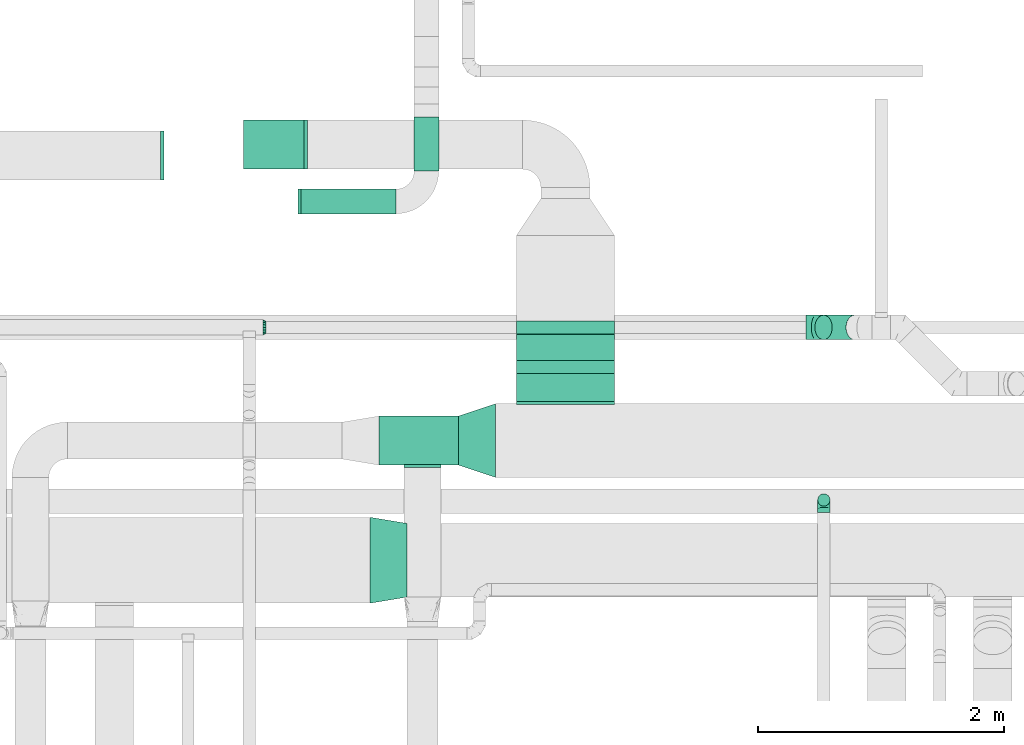
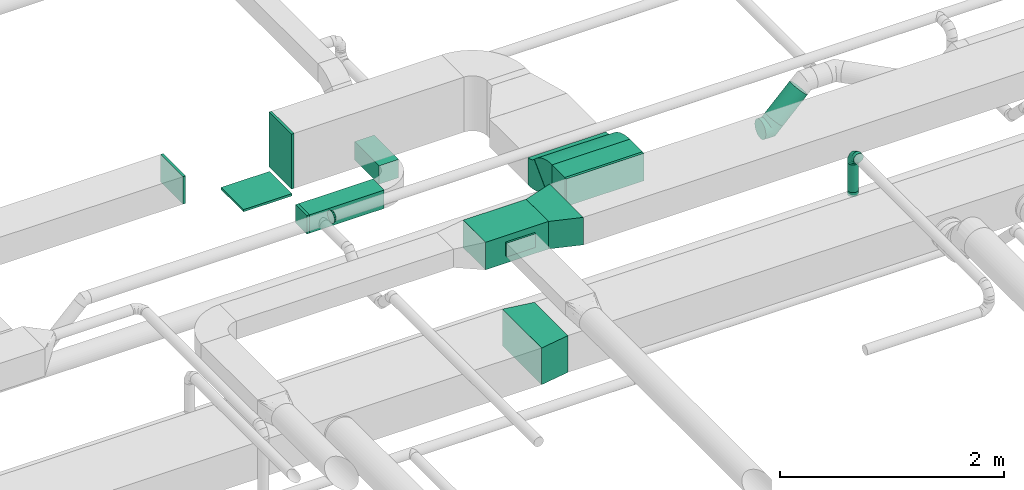
# One storey, part 39 of 60: 14 flow fittings, 7 flow segments.
"""IFC2X3 building model written with IfcOpenShell, lengths in millimetres."""

from ifc_helpers import new_model, entity, si_unit, converted_unit, derived_unit, direction, frame, frame_2d, origin, origin_2d_with_axis, place, context, subcontext, project, spatial, polyline, circle_curve, parameter, trimmed, segment, composite_curve, rectangle, circle, outline, extrude, faceted_brep, source, transform, mapped, material, type_object, type_shapes, element, save


model = new_model("IFC2X3")

# Units and contexts
model_context = context("Model", 3, precision=0.01, world=origin(), true_north=direction((6.12303176911189e-17, 1.0)))
body_context = subcontext(model_context, "Body", "Model", "MODEL_VIEW")
ifc_project = project(units=[si_unit("LENGTHUNIT", "METRE", prefix="MILLI"), si_unit("AREAUNIT", "SQUARE_METRE"), si_unit("VOLUMEUNIT", "CUBIC_METRE"), converted_unit("PLANEANGLEUNIT", "DEGREE", entity("IfcRatioMeasure", 0.0174532925199433), si_unit("PLANEANGLEUNIT", "RADIAN"), dimensions=[0, 0, 0, 0, 0, 0, 0]), si_unit("MASSUNIT", "GRAM", prefix="KILO"), derived_unit("MASSDENSITYUNIT", [(si_unit("MASSUNIT", "GRAM", prefix="KILO"), 1), (si_unit("LENGTHUNIT", "METRE"), -3)]), derived_unit("MOMENTOFINERTIAUNIT", [(si_unit("LENGTHUNIT", "METRE"), 4)]), si_unit("TIMEUNIT", "SECOND"), si_unit("FREQUENCYUNIT", "HERTZ"), si_unit("THERMODYNAMICTEMPERATUREUNIT", "DEGREE_CELSIUS"), derived_unit("THERMALTRANSMITTANCEUNIT", [(si_unit("MASSUNIT", "GRAM", prefix="KILO"), 1), (si_unit("THERMODYNAMICTEMPERATUREUNIT", "KELVIN"), -1), (si_unit("TIMEUNIT", "SECOND"), -3)]), derived_unit("VOLUMETRICFLOWRATEUNIT", [(si_unit("LENGTHUNIT", "METRE"), 3), (si_unit("TIMEUNIT", "SECOND"), -1)]), derived_unit("MASSFLOWRATEUNIT", [(si_unit("MASSUNIT", "GRAM", prefix="KILO"), 1), (si_unit("TIMEUNIT", "SECOND"), -1)]), derived_unit("ROTATIONALFREQUENCYUNIT", [(si_unit("TIMEUNIT", "SECOND"), -1)]), si_unit("ELECTRICCURRENTUNIT", "AMPERE"), si_unit("ELECTRICVOLTAGEUNIT", "VOLT"), si_unit("POWERUNIT", "WATT"), si_unit("FORCEUNIT", "NEWTON", prefix="KILO"), si_unit("ILLUMINANCEUNIT", "LUX"), si_unit("LUMINOUSFLUXUNIT", "LUMEN"), si_unit("LUMINOUSINTENSITYUNIT", "CANDELA"), derived_unit("USERDEFINED", [(si_unit("MASSUNIT", "GRAM", prefix="KILO"), -1), (si_unit("LENGTHUNIT", "METRE"), -2), (si_unit("TIMEUNIT", "SECOND"), 3), (si_unit("LUMINOUSFLUXUNIT", "LUMEN"), 1)]), derived_unit("LINEARVELOCITYUNIT", [(si_unit("LENGTHUNIT", "METRE"), 1), (si_unit("TIMEUNIT", "SECOND"), -1)]), si_unit("PRESSUREUNIT", "PASCAL"), derived_unit("USERDEFINED", [(si_unit("LENGTHUNIT", "METRE"), -2), (si_unit("MASSUNIT", "GRAM", prefix="KILO"), 1), (si_unit("TIMEUNIT", "SECOND"), -2)]), derived_unit("LINEARFORCEUNIT", [(si_unit("MASSUNIT", "GRAM", prefix="KILO"), 1), (si_unit("LENGTHUNIT", "METRE"), 1), (si_unit("TIMEUNIT", "SECOND"), -2), (si_unit("LENGTHUNIT", "METRE"), -1)]), derived_unit("PLANARFORCEUNIT", [(si_unit("MASSUNIT", "GRAM", prefix="KILO"), 1), (si_unit("LENGTHUNIT", "METRE"), 1), (si_unit("TIMEUNIT", "SECOND"), -2), (si_unit("LENGTHUNIT", "METRE"), -2)])], contexts=[model_context])

# Site, building, storey
site_placement = place(None, origin())
site = spatial("IfcSite", under=ifc_project, at=site_placement, CompositionType="ELEMENT")
building_placement = place(site_placement, origin())
building = spatial("IfcBuilding", under=site, at=building_placement, CompositionType="ELEMENT")
storey_placement = place(building_placement, frame((0.0, 0.0, 19800.0)))
storey = spatial("IfcBuildingStorey", under=building, at=storey_placement, CompositionType="ELEMENT", Elevation=19800.0)

# Flow segments
duct_segment_type_1 = type_object("IfcDuctSegmentType", PredefinedType="NOTDEFINED")
flow_segment_1_placement = place(storey_placement, frame((53402.88, 9163.95, 3420.0)))
element("IfcFlowSegment", 1, at=flow_segment_1_placement, inside=storey, type_object=duct_segment_type_1, context=body_context, shape_type="SweptSolid", body=[
    extrude(rectangle(XDim=650.000000000069, YDim=400.0, at=origin_2d_with_axis()), frame((325.0, 200.0, 0.0)), (0.0, 0.0, 1.0), 300.000000000001),
])
flow_segment_2_placement = place(storey_placement, frame((52770.03, 11210.73, 2800.0)))
element("IfcFlowSegment", 2, at=flow_segment_2_placement, inside=storey, type_object=duct_segment_type_1, context=body_context, shape_type="SweptSolid", body=[
    extrude(rectangle(XDim=770.426926812535, YDim=200.0, at=origin_2d_with_axis()), frame((385.21, 100.0, 0.0)), (0.0, 0.0, 1.0), 199.999999999998),
])
flow_segment_3_placement = place(storey_placement, frame((53690.46, 11560.73, 2800.0)))
element("IfcFlowSegment", 3, at=flow_segment_3_placement, inside=storey, type_object=duct_segment_type_1, context=body_context, shape_type="SweptSolid", body=[
    extrude(rectangle(XDim=436.446609406733, YDim=199.999999999998, at=origin_2d_with_axis()), frame((100.0, 218.22, 0.0), z_axis=(0.0, 0.0, 1.0), x_axis=(0.0, 1.0, 0.0)), (0.0, 0.0, 1.0), 199.999999999998),
])
flow_segment_4_placement = place(storey_placement, frame((54521.8, 10017.07, 3371.8)))
element("IfcFlowSegment", 4, at=flow_segment_4_placement, inside=storey, type_object=duct_segment_type_1, context=body_context, shape_type="SweptSolid", body=[
    extrude(rectangle(XDim=6.03030380317478, YDim=299.999999999998, at=origin_2d_with_axis()), frame((0.0, 108.2, 108.2), z_axis=(1.0, 0.0, 0.0), x_axis=(0.0, -0.707106781186548, 0.707106781186548)), (0.0, 0.0, 1.0), 800.000000000008),
])
flow_segment_5_placement = place(storey_placement, frame((54521.8, 9683.95, 3420.0)))
element("IfcFlowSegment", 5, at=flow_segment_5_placement, inside=storey, type_object=duct_segment_type_1, context=body_context, shape_type="SweptSolid", body=[
    extrude(rectangle(XDim=227.051120466258, YDim=800.0, at=origin_2d_with_axis()), frame((400.0, 113.53, 0.0), z_axis=(0.0, 0.0, 1.0), x_axis=(0.0, 1.0, 0.0)), (0.0, 0.0, 1.0), 300.000000000001),
])
duct_segment_type_2 = type_object("IfcDuctSegmentType", PredefinedType="NOTDEFINED")
flow_segment_6_placement = place(storey_placement, frame((56974.72, 8828.41, 3199.5)))
element("IfcFlowSegment", 6, at=flow_segment_6_placement, inside=storey, type_object=duct_segment_type_2, context=body_context, shape_type="SweptSolid", body=[
    extrude(circle(Radius=50.0, at=origin_2d_with_axis()), frame((51.6, 51.6, 0.0), z_axis=(0.0, 0.0, 1.0), x_axis=(-1.0, 0.0, 0.0)), (0.0, 0.0, 1.0), 300.501256289336),
])
flow_segment_7_placement = place(storey_placement, frame((56951.59, 10184.02, 3041.27)))
element("IfcFlowSegment", 7, at=flow_segment_7_placement, inside=storey, type_object=duct_segment_type_2, context=body_context, shape_type="SweptSolid", body=[
    extrude(circle(Radius=100.0, at=origin_2d_with_axis()), frame((72.31, 101.6, 72.31), z_axis=(0.707106781186555, 0.0, 0.70710678118654), x_axis=(0.0, -1.0, 0.0)), (0.0, 0.0, 1.0), 359.208612625993),
])

# Flow fittings
ifc_material = material()
duct_fitting_type_1 = type_object("IfcDuctFittingType", PredefinedType="NOTDEFINED", material=ifc_material)
shared_shape_1 = source(origin(), body_context, "Body", "SweptSolid", [
    extrude(rectangle(XDim=26.0960000000436, YDim=200.0, at=origin_2d_with_axis()), frame((6.95, 0.0, -100.0)), (0.0, 0.0, 1.0), 200.0),
])
type_shapes(duct_fitting_type_1, [shared_shape_1])
flow_fitting_1_placement = place(storey_placement, frame((52750.03, 11310.73, 2900.0), z_axis=(0.0, -1.0, 0.0), x_axis=(1.0, 0.0, 0.0)))
element("IfcFlowFitting", 8, at=flow_fitting_1_placement, inside=storey, type_object=duct_fitting_type_1, material=ifc_material, context=body_context, shape_type="MappedRepresentation", body=[
    mapped(shared_shape_1, transform((0.0, 0.0, 0.0), scale=1.0)),
])
duct_fitting_type_2 = type_object("IfcDuctFittingType", PredefinedType="NOTDEFINED", material=ifc_material)
shared_shape_2 = source(origin(), body_context, "Body", "SweptSolid", [
    extrude(rectangle(XDim=26.0960000000546, YDim=300.0, at=origin_2d_with_axis()), frame((6.95, 0.0, -200.0)), (0.0, 0.0, 1.0), 400.0),
])
type_shapes(duct_fitting_type_2, [shared_shape_2])
flow_fitting_2_placement = place(storey_placement, frame((51645.21, 11685.34, 3500.0), z_axis=(0.0, 1.0, 0.0), x_axis=(-1.0, 0.0, 0.0)))
element("IfcFlowFitting", 9, at=flow_fitting_2_placement, inside=storey, type_object=duct_fitting_type_2, material=ifc_material, context=body_context, shape_type="MappedRepresentation", body=[
    mapped(shared_shape_2, transform((0.0, 0.0, 0.0), scale=1.0)),
])
duct_fitting_type_3 = type_object("IfcDuctFittingType", PredefinedType="NOTDEFINED", material=ifc_material)
shared_shape_3 = source(origin(), body_context, "Body", "SweptSolid", [
    extrude(rectangle(XDim=26.0960000000005, YDim=300.0, at=origin_2d_with_axis()), frame((6.95, 0.0, -75.0)), (0.0, 0.0, 1.0), 150.0),
])
type_shapes(duct_fitting_type_3, [shared_shape_3])
flow_fitting_3_placement = place(storey_placement, frame((53758.41, 9163.95, 3575.0), z_axis=(0.0, 0.0, -1.0), x_axis=(0.0, -1.0, 0.0)))
element("IfcFlowFitting", 10, at=flow_fitting_3_placement, inside=storey, type_object=duct_fitting_type_3, material=ifc_material, context=body_context, shape_type="MappedRepresentation", body=[
    mapped(shared_shape_3, transform((0.0, 0.0, 0.0), scale=1.0)),
])
duct_fitting_type_4 = type_object("IfcDuctFittingType", PredefinedType="NOTDEFINED", material=ifc_material)
shared_shape_4 = source(origin(), body_context, "Body", "SweptSolid", [
    extrude(outline(polyline([(-98.64, -320.58), (205.5, -320.58), (90.42, 369.9), (-197.28, 271.26), (-98.64, -320.58)])), frame((150.0, 0.0, -200.0), z_axis=(0.0, 0.0, 1.0), x_axis=(0.986393923832143, -0.164398987305359, 0.0)), (0.0, 0.0, 1.0), 400.0),
])
type_shapes(duct_fitting_type_4, [shared_shape_4])
flow_fitting_4_placement = place(storey_placement, frame((53632.16, 8389.45, 3074.9), z_axis=(-8.18553681048441e-06, 0.0, 1.0), x_axis=(-1.0, 0.0, -8.18553681048441e-06)))
element("IfcFlowFitting", 11, at=flow_fitting_4_placement, inside=storey, type_object=duct_fitting_type_4, material=ifc_material, context=body_context, shape_type="MappedRepresentation", body=[
    mapped(shared_shape_4, transform((0.0, 0.0, 0.0), scale=1.0)),
])
duct_fitting_type_5 = type_object("IfcDuctFittingType", PredefinedType="NOTDEFINED", material=ifc_material)
shared_shape_5 = source(origin(), body_context, "Body", "SweptSolid", [
    extrude(rectangle(XDim=26.0960000000009, YDim=600.0, at=origin_2d_with_axis()), frame((6.95, 0.0, -200.0)), (0.0, 0.0, 1.0), 400.0),
])
type_shapes(duct_fitting_type_5, [shared_shape_5])
flow_fitting_5_placement = place(storey_placement, frame((52800.35, 11773.78, 3350.0), z_axis=(0.0, -1.0, 0.0), x_axis=(1.0, 0.0, 0.0)))
element("IfcFlowFitting", 12, at=flow_fitting_5_placement, inside=storey, type_object=duct_fitting_type_5, material=ifc_material, context=body_context, shape_type="MappedRepresentation", body=[
    mapped(shared_shape_5, transform((0.0, 0.0, 0.0), scale=1.0)),
])
duct_fitting_type_6 = type_object("IfcDuctFittingType", PredefinedType="NOTDEFINED", material=ifc_material)
shared_shape_6 = source(origin(), body_context, "Body", "SweptSolid", [
    extrude(rectangle(XDim=24.9999999999999, YDim=400.0, at=origin_2d_with_axis()), frame((12.5, 0.0, -250.0)), (0.0, 0.0, 1.0), 500.0),
])
type_shapes(duct_fitting_type_6, [shared_shape_6])
flow_fitting_6_placement = place(storey_placement, frame((52550.35, 11773.64, 3001.14), z_axis=(1.0, 0.0, 0.0), x_axis=(0.0, 0.0, -1.0)))
element("IfcFlowFitting", 13, at=flow_fitting_6_placement, inside=storey, type_object=duct_fitting_type_6, material=ifc_material, context=body_context, shape_type="MappedRepresentation", body=[
    mapped(shared_shape_6, transform((0.0, 0.0, 0.0), scale=1.0)),
])
duct_fitting_type_7 = type_object("IfcDuctFittingType", PredefinedType="NOTDEFINED", material=ifc_material)
shared_shape_7 = source(origin(), body_context, "Body", "SweptSolid", [
    extrude(outline(polyline([(-79.06, -237.17), (237.17, -237.17), (47.43, 332.04), (-205.55, 142.3), (-79.06, -237.17)])), frame((150.0, 0.0, -150.0), z_axis=(0.0, 0.0, 1.0), x_axis=(0.948683298050513, -0.31622776601684, 0.0)), (0.0, 0.0, 1.0), 300.0),
])
type_shapes(duct_fitting_type_7, [shared_shape_7])
flow_fitting_7_placement = place(storey_placement, frame((54052.88, 9363.95, 3570.0)))
element("IfcFlowFitting", 14, at=flow_fitting_7_placement, inside=storey, type_object=duct_fitting_type_7, material=ifc_material, context=body_context, shape_type="MappedRepresentation", body=[
    mapped(shared_shape_7, transform((0.0, 0.0, 0.0), scale=1.0)),
])
duct_fitting_type_8 = type_object("IfcDuctFittingType", PredefinedType="NOTDEFINED", material=ifc_material)
shared_shape_8 = source(origin(), body_context, "Body", "SweptSolid", [
    extrude(rectangle(XDim=800.0, YDim=26.0960000000054, at=origin_2d_with_axis()), frame((6.95, 0.0, -150.0), z_axis=(0.0, 0.0, 1.0), x_axis=(0.0, -1.0, 0.0)), (0.0, 0.0, 1.0), 300.0),
])
type_shapes(duct_fitting_type_8, [shared_shape_8])
flow_fitting_8_placement = place(storey_placement, frame((54921.8, 9663.95, 3570.0), z_axis=(0.0, 0.0, -1.0), x_axis=(0.0, 1.0, 0.0)))
element("IfcFlowFitting", 15, at=flow_fitting_8_placement, inside=storey, type_object=duct_fitting_type_8, material=ifc_material, context=body_context, shape_type="MappedRepresentation", body=[
    mapped(shared_shape_8, transform((0.0, 0.0, 0.0), scale=1.0)),
])
duct_fitting_type_9 = type_object("IfcDuctFittingType", PredefinedType="NOTDEFINED", material=ifc_material)
shared_shape_9 = source(origin(), body_context, "Body", "Brep", [
    faceted_brep([(-100.0, 0.0, -50.0), (-100.0, -12.94, -48.3), (-100.0, -25.0, -43.3), (-100.0, -35.36, -35.36), (-100.0, -43.3, -25.0), (-100.0, -48.3, -12.94), (-100.0, -50.0, 0.0), (-100.0, -48.3, 12.94), (-100.0, -43.3, 25.0), (-100.0, -35.36, 35.36), (-100.0, -25.0, 43.3), (-100.0, -12.94, 48.3), (-100.0, 0.0, 50.0), (-100.0, 12.94, 48.3), (-100.0, 25.0, 43.3), (-100.0, 35.36, 35.36), (-100.0, 43.3, 25.0), (-100.0, 48.3, 12.94), (-100.0, 50.0, 0.0), (-100.0, 48.3, -12.94), (-100.0, 43.3, -25.0), (-100.0, 35.36, -35.36), (-100.0, 25.0, -43.3), (-100.0, 12.94, -48.3), (-76.67, 12.94, 48.3), (-79.9, 25.0, 43.3), (-73.21, 0.0, 50.0), (-82.68, 35.36, 35.36), (-86.15, 48.3, 12.94), (-86.6, 50.0, 0.0), (-84.81, 43.3, 25.0), (-84.81, 43.3, -25.0), (-82.68, 35.36, -35.36), (-86.15, 48.3, -12.94), (-76.67, 12.94, -48.3), (-73.21, 0.0, -50.0), (-79.9, 25.0, -43.3), (-69.74, -12.94, -48.3), (-66.51, -25.0, -43.3), (-63.73, -35.36, -35.36), (-61.6, -43.3, -25.0), (-60.26, -48.3, -12.94), (-59.81, -50.0, 0.0), (-60.26, -48.3, 12.94), (-61.6, -43.3, 25.0), (-63.73, -35.36, 35.36), (-66.51, -25.0, 43.3), (-69.74, -12.94, 48.3), (-36.27, 36.27, 48.3), (-45.1, 45.1, 43.3), (-26.79, 26.79, 50.0), (-52.68, 52.68, 35.36), (-58.49, 58.49, 25.0), (-62.15, 62.15, 12.94), (-63.4, 63.4, 0.0), (-62.15, 62.15, -12.94), (-58.49, 58.49, -25.0), (-52.68, 52.68, -35.36), (-36.27, 36.27, -48.3), (-26.79, 26.79, -50.0), (-45.1, 45.1, -43.3), (-17.32, 17.32, -48.3), (-8.49, 8.49, -43.3), (-0.91, 0.91, -35.36), (4.9, -4.9, -25.0), (8.56, -8.56, -12.94), (9.81, -9.81, 0.0), (8.56, -8.56, 12.94), (4.9, -4.9, 25.0), (-0.91, 0.91, 35.36), (-8.49, 8.49, 43.3), (-17.32, 17.32, 48.3), (-12.94, 76.67, 48.3), (-25.0, 79.9, 43.3), (0.0, 73.21, 50.0), (-35.36, 82.68, 35.36), (-43.3, 84.81, 25.0), (-48.3, 86.15, 12.94), (-50.0, 86.6, 0.0), (-48.3, 86.15, -12.94), (-43.3, 84.81, -25.0), (-35.36, 82.68, -35.36), (-12.94, 76.67, -48.3), (0.0, 73.21, -50.0), (-25.0, 79.9, -43.3), (12.94, 69.74, -48.3), (25.0, 66.51, -43.3), (35.36, 63.73, -35.36), (43.3, 61.6, -25.0), (48.3, 60.26, -12.94), (50.0, 59.81, 0.0), (48.3, 60.26, 12.94), (43.3, 61.6, 25.0), (35.36, 63.73, 35.36), (25.0, 66.51, 43.3), (12.94, 69.74, 48.3), (-12.94, 100.0, -48.3), (-25.0, 100.0, -43.3), (-35.36, 100.0, -35.36), (-43.3, 100.0, -25.0), (-48.3, 100.0, -12.94), (-50.0, 100.0, 0.0), (-48.3, 100.0, 12.94), (-43.3, 100.0, 25.0), (-35.36, 100.0, 35.36), (-25.0, 100.0, 43.3), (-12.94, 100.0, 48.3), (0.0, 100.0, 50.0), (12.94, 100.0, 48.3), (25.0, 100.0, 43.3), (35.36, 100.0, 35.36), (43.3, 100.0, 25.0), (48.3, 100.0, 12.94), (50.0, 100.0, 0.0), (48.3, 100.0, -12.94), (43.3, 100.0, -25.0), (35.36, 100.0, -35.36), (25.0, 100.0, -43.3), (12.94, 100.0, -48.3), (0.0, 100.0, -50.0)], [[[0, 1, 2, 3, 4, 5, 6, 7, 8, 9, 10, 11, 12, 13, 14, 15, 16, 17, 18, 19, 20, 21, 22, 23]], [[24, 25, 14, 13]], [[26, 24, 13, 12]], [[14, 25, 27, 15]], [[28, 29, 18, 17]], [[30, 28, 17, 16]], [[15, 27, 30, 16]], [[20, 31, 32, 21]], [[33, 31, 20, 19]], [[18, 29, 33, 19]], [[34, 35, 0, 23]], [[36, 34, 23, 22]], [[32, 36, 22, 21]], [[2, 1, 37, 38]], [[3, 2, 38, 39]], [[0, 35, 37, 1]], [[5, 4, 40, 41]], [[6, 5, 41, 42]], [[3, 39, 40, 4]], [[6, 42, 43, 7]], [[7, 43, 44, 8]], [[8, 44, 45, 9]], [[10, 46, 47, 11]], [[11, 47, 26, 12]], [[10, 9, 45, 46]], [[48, 49, 25, 24]], [[50, 48, 24, 26]], [[27, 25, 49, 51]], [[52, 53, 28, 30]], [[51, 52, 30, 27]], [[29, 28, 53, 54]], [[55, 56, 31, 33]], [[54, 55, 33, 29]], [[57, 32, 31, 56]], [[58, 59, 35, 34]], [[60, 58, 34, 36]], [[57, 60, 36, 32]], [[37, 35, 59, 61]], [[38, 37, 61, 62]], [[39, 38, 62, 63]], [[41, 40, 64, 65]], [[42, 41, 65, 66]], [[63, 64, 40, 39]], [[43, 42, 66, 67]], [[44, 43, 67, 68]], [[68, 69, 45, 44]], [[46, 45, 69, 70]], [[47, 46, 70, 71]], [[26, 47, 71, 50]], [[72, 73, 49, 48]], [[74, 72, 48, 50]], [[51, 49, 73, 75]], [[76, 77, 53, 52]], [[75, 76, 52, 51]], [[54, 53, 77, 78]], [[79, 80, 56, 55]], [[78, 79, 55, 54]], [[81, 57, 56, 80]], [[82, 83, 59, 58]], [[84, 82, 58, 60]], [[81, 84, 60, 57]], [[61, 59, 83, 85]], [[62, 61, 85, 86]], [[63, 62, 86, 87]], [[65, 64, 88, 89]], [[66, 65, 89, 90]], [[87, 88, 64, 63]], [[67, 66, 90, 91]], [[68, 67, 91, 92]], [[92, 93, 69, 68]], [[70, 69, 93, 94]], [[71, 70, 94, 95]], [[50, 71, 95, 74]], [[96, 97, 98, 99, 100, 101, 102, 103, 104, 105, 106, 107, 108, 109, 110, 111, 112, 113, 114, 115, 116, 117, 118, 119]], [[72, 74, 107, 106]], [[73, 72, 106, 105]], [[75, 73, 105, 104]], [[77, 76, 103, 102]], [[78, 77, 102, 101]], [[75, 104, 103, 76]], [[78, 101, 100, 79]], [[79, 100, 99, 80]], [[80, 99, 98, 81]], [[96, 119, 83, 82]], [[97, 96, 82, 84]], [[84, 81, 98, 97]], [[83, 119, 118, 85]], [[85, 118, 117, 86]], [[86, 117, 116, 87]], [[88, 115, 114, 89]], [[89, 114, 113, 90]], [[87, 116, 115, 88]], [[91, 90, 113, 112]], [[92, 91, 112, 111]], [[93, 92, 111, 110]], [[95, 94, 109, 108]], [[74, 95, 108, 107]], [[110, 109, 94, 93]]]),
])
type_shapes(duct_fitting_type_9, [shared_shape_9])
flow_fitting_9_placement = place(storey_placement, frame((57026.32, 8880.01, 3600.0), z_axis=(1.0, 0.0, 0.0), x_axis=(0.0, 0.0, 1.0)))
element("IfcFlowFitting", 16, at=flow_fitting_9_placement, inside=storey, type_object=duct_fitting_type_9, material=ifc_material, context=body_context, shape_type="MappedRepresentation", body=[
    mapped(shared_shape_9, transform((0.0, 0.0, 0.0), scale=1.0)),
])
duct_fitting_type_10 = type_object("IfcDuctFittingType", PredefinedType="NOTDEFINED", material=ifc_material)
shared_shape_10 = source(origin(), body_context, "Body", "Brep", [
    faceted_brep([(-82.84, 0.0, -100.0), (-82.84, -25.88, -96.59), (-82.84, -50.0, -86.6), (-82.84, -70.71, -70.71), (-82.84, -86.6, -50.0), (-82.84, -96.59, -25.88), (-82.84, -100.0, 0.0), (-82.84, -96.59, 25.88), (-82.84, -86.6, 50.0), (-82.84, -70.71, 70.71), (-82.84, -50.0, 86.6), (-82.84, -25.88, 96.59), (-82.84, 0.0, 100.0), (-82.84, 25.88, 96.59), (-82.84, 50.0, 86.6), (-82.84, 70.71, 70.71), (-82.84, 86.6, 50.0), (-82.84, 96.59, 25.88), (-82.84, 100.0, 0.0), (-82.84, 96.59, -25.88), (-82.84, 86.6, -50.0), (-82.84, 70.71, -70.71), (-82.84, 50.0, -86.6), (-82.84, 25.88, -96.59), (-10.72, 25.88, 96.59), (-20.71, 50.0, 86.6), (0.0, 0.0, 100.0), (-29.29, 70.71, 70.71), (-35.87, 86.6, 50.0), (-40.01, 96.59, 25.88), (-41.42, 100.0, 0.0), (-40.01, 96.59, -25.88), (-35.87, 86.6, -50.0), (-29.29, 70.71, -70.71), (-10.72, 25.88, -96.59), (0.0, 0.0, -100.0), (-20.71, 50.0, -86.6), (10.72, -25.88, -96.59), (20.71, -50.0, -86.6), (29.29, -70.71, -70.71), (35.87, -86.6, -50.0), (40.01, -96.59, -25.88), (41.42, -100.0, 0.0), (40.01, -96.59, 25.88), (35.87, -86.6, 50.0), (29.29, -70.71, 70.71), (20.71, -50.0, 86.6), (10.72, -25.88, 96.59), (58.58, 58.58, 100.0), (40.28, 76.88, 96.59), (23.22, 93.93, 86.6), (8.58, 108.58, 70.71), (-2.66, 119.82, 50.0), (-9.72, 126.88, 25.88), (-12.13, 129.29, 0.0), (-9.72, 126.88, -25.88), (-2.66, 119.82, -50.0), (8.58, 108.58, -70.71), (23.22, 93.93, -86.6), (40.28, 76.88, -96.59), (58.58, 58.58, -100.0), (76.88, 40.28, -96.59), (93.93, 23.22, -86.6), (108.58, 8.58, -70.71), (119.82, -2.66, -50.0), (126.88, -9.72, -25.88), (129.29, -12.13, 0.0), (126.88, -9.72, 25.88), (119.82, -2.66, 50.0), (108.58, 8.58, 70.71), (93.93, 23.22, 86.6), (76.88, 40.28, 96.59)], [[[0, 1, 2, 3, 4, 5, 6, 7, 8, 9, 10, 11, 12, 13, 14, 15, 16, 17, 18, 19, 20, 21, 22, 23]], [[24, 25, 14, 13]], [[26, 24, 13, 12]], [[14, 25, 27, 15]], [[28, 29, 17, 16]], [[28, 16, 15, 27]], [[30, 18, 17, 29]], [[31, 32, 20, 19]], [[30, 31, 19, 18]], [[32, 33, 21, 20]], [[34, 35, 0, 23]], [[36, 34, 23, 22]], [[33, 36, 22, 21]], [[1, 0, 35, 37]], [[2, 1, 37, 38]], [[38, 39, 3, 2]], [[5, 4, 40, 41]], [[6, 5, 41, 42]], [[39, 40, 4, 3]], [[6, 42, 43, 7]], [[7, 43, 44, 8]], [[8, 44, 45, 9]], [[9, 45, 46, 10]], [[10, 46, 47, 11]], [[26, 12, 11, 47]], [[24, 26, 48, 49]], [[25, 24, 49, 50]], [[27, 25, 50, 51]], [[29, 28, 52, 53]], [[30, 29, 53, 54]], [[51, 52, 28, 27]], [[30, 54, 55, 31]], [[31, 55, 56, 32]], [[57, 33, 32, 56]], [[36, 58, 59, 34]], [[34, 59, 60, 35]], [[58, 36, 33, 57]], [[35, 60, 61, 37]], [[37, 61, 62, 38]], [[63, 39, 38, 62]], [[40, 64, 65, 41]], [[41, 65, 66, 42]], [[64, 40, 39, 63]], [[43, 42, 66, 67]], [[44, 43, 67, 68]], [[68, 69, 45, 44]], [[47, 46, 70, 71]], [[26, 47, 71, 48]], [[69, 70, 46, 45]], [[59, 58, 57, 56, 55, 54, 53, 52, 51, 50, 49, 48, 71, 70, 69, 68, 67, 66, 65, 64, 63, 62, 61, 60]]]),
])
type_shapes(duct_fitting_type_10, [shared_shape_10])
flow_fitting_10_placement = place(storey_placement, frame((56965.32, 10285.62, 3055.0), z_axis=(0.0, 1.0, 0.0), x_axis=(-0.707106781186538, 0.0, -0.707106781186557)))
element("IfcFlowFitting", 17, at=flow_fitting_10_placement, inside=storey, type_object=duct_fitting_type_10, material=ifc_material, context=body_context, shape_type="MappedRepresentation", body=[
    mapped(shared_shape_10, transform((0.0, 0.0, 0.0), scale=1.0)),
])
duct_fitting_type_11 = type_object("IfcDuctFittingType", PredefinedType="NOTDEFINED", material=ifc_material)
shared_shape_11 = source(origin(), body_context, "Body", "Brep", [
    faceted_brep([(25.0, 0.0, -62.5), (25.0, 12.45, -60.02), (25.0, 23.92, -57.74), (25.0, 34.06, -50.97), (25.0, 44.19, -44.19), (25.0, 50.97, -34.06), (25.0, 57.74, -23.92), (25.0, 60.02, -12.45), (25.0, 62.5, 0.0), (25.0, 60.02, 12.45), (25.0, 57.74, 23.92), (25.0, 50.97, 34.06), (25.0, 44.19, 44.19), (25.0, 34.06, 50.97), (25.0, 23.92, 57.74), (25.0, 12.45, 60.02), (25.0, 0.0, 62.5), (25.0, -12.45, 60.02), (25.0, -23.92, 57.74), (25.0, -34.06, 50.97), (25.0, -44.19, 44.19), (25.0, -50.97, 34.06), (25.0, -57.74, 23.92), (25.0, -60.02, 12.45), (25.0, -62.5, 0.0), (25.0, -60.02, -12.45), (25.0, -57.74, -23.92), (25.0, -50.97, -34.06), (25.0, -44.19, -44.19), (25.0, -34.06, -50.97), (25.0, -23.92, -57.74), (25.0, -12.45, -60.02), (0.0, -19.13, -46.19), (0.0, -27.24, -40.77), (0.0, -35.36, -35.36), (0.0, -40.77, -27.24), (0.0, -46.19, -19.13), (0.0, -48.1, -9.57), (0.0, -50.0, 0.0), (0.0, -48.1, 9.57), (0.0, -46.19, 19.13), (0.0, -40.77, 27.24), (0.0, -35.36, 35.36), (0.0, -27.24, 40.77), (0.0, -19.13, 46.19), (0.0, -9.57, 48.1), (0.0, 0.0, 50.0), (0.0, 9.57, 48.1), (0.0, 19.13, 46.19), (0.0, 27.24, 40.77), (0.0, 35.36, 35.36), (0.0, 40.77, 27.24), (0.0, 46.19, 19.13), (0.0, 48.1, 9.57), (0.0, 50.0, 0.0), (0.0, 48.1, -9.57), (0.0, 46.19, -19.13), (0.0, 40.77, -27.24), (0.0, 35.36, -35.36), (0.0, 27.24, -40.77), (0.0, 19.13, -46.19), (0.0, 9.57, -48.1), (0.0, 0.0, -50.0), (0.0, -9.57, -48.1)], [[[0, 1, 2, 3, 4, 5, 6, 7, 8, 9, 10, 11, 12, 13, 14, 15, 16, 17, 18, 19, 20, 21, 22, 23, 24, 25, 26, 27, 28, 29, 30, 31]], [[32, 33, 34, 35, 36, 37, 38, 39, 40, 41, 42, 43, 44, 45, 46, 47, 48, 49, 50, 51, 52, 53, 54, 55, 56, 57, 58, 59, 60, 61, 62, 63]], [[52, 10, 9, 8, 54, 53]], [[51, 50, 12, 11, 10, 52]], [[47, 46, 16, 15, 14, 48]], [[49, 48, 14, 13, 12, 50]], [[44, 18, 17, 16, 46, 45]], [[43, 42, 20, 19, 18, 44]], [[39, 38, 24, 23, 22, 40]], [[41, 40, 22, 21, 20, 42]], [[36, 26, 25, 24, 38, 37]], [[35, 34, 28, 27, 26, 36]], [[63, 62, 0, 31, 30, 32]], [[33, 32, 30, 29, 28, 34]], [[60, 2, 1, 0, 62, 61]], [[59, 58, 4, 3, 2, 60]], [[55, 54, 8, 7, 6, 56]], [[57, 56, 6, 5, 4, 58]]]),
])
type_shapes(duct_fitting_type_11, [shared_shape_11])
flow_fitting_11_placement = place(storey_placement, frame((52482.7, 10285.62, 3650.0), z_axis=(0.0, 0.0, 1.0), x_axis=(-1.0, 0.0, 0.0)))
element("IfcFlowFitting", 18, at=flow_fitting_11_placement, inside=storey, type_object=duct_fitting_type_11, material=ifc_material, context=body_context, shape_type="MappedRepresentation", body=[
    mapped(shared_shape_11, transform((0.0, 0.0, 0.0), scale=1.0)),
])
duct_fitting_type_12 = type_object("IfcDuctFittingType", PredefinedType="NOTDEFINED", material=ifc_material)
shared_shape_12 = source(origin(), body_context, "Body", "Brep", [
    faceted_brep([(20.0, 12.94, -48.3), (20.0, 25.0, -43.3), (20.0, 35.36, -35.36), (20.0, 43.3, -25.0), (20.0, 48.3, -12.94), (20.0, 50.0, 0.0), (20.0, 48.3, 12.94), (20.0, 43.3, 25.0), (20.0, 35.36, 35.36), (20.0, 25.0, 43.3), (20.0, 12.94, 48.3), (20.0, 0.0, 50.0), (20.0, -12.94, 48.3), (20.0, -25.0, 43.3), (20.0, -35.36, 35.36), (20.0, -43.3, 25.0), (20.0, -48.3, 12.94), (20.0, -50.0, 0.0), (20.0, -48.3, -12.94), (20.0, -43.3, -25.0), (20.0, -35.36, -35.36), (20.0, -25.0, -43.3), (20.0, -12.94, -48.3), (20.0, 0.0, -50.0), (0.0, 0.0, 50.0), (0.0, 12.94, 48.3), (-25.59, 12.94, 48.3), (-25.59, 0.0, 50.0), (0.0, 25.0, 43.3), (-25.59, 25.0, 43.3), (0.0, 35.36, 35.36), (-25.59, 35.36, 35.36), (0.0, 43.3, 25.0), (0.0, 48.3, 12.94), (-25.59, 48.3, 12.94), (-25.59, 43.3, 25.0), (0.0, 50.0, 0.0), (-25.59, 50.0, 0.0), (0.0, 48.3, -12.94), (-25.59, 48.3, -12.94), (0.0, 43.3, -25.0), (-25.59, 43.3, -25.0), (0.0, 35.36, -35.36), (-25.59, 35.36, -35.36), (0.0, 25.0, -43.3), (0.0, 12.94, -48.3), (-25.59, 12.94, -48.3), (-25.59, 25.0, -43.3), (0.0, 0.0, -50.0), (-25.59, 0.0, -50.0), (0.0, -12.94, -48.3), (-25.59, -12.94, -48.3), (0.0, -25.0, -43.3), (-25.59, -25.0, -43.3), (0.0, -35.36, -35.36), (-25.59, -35.36, -35.36), (0.0, -43.3, -25.0), (0.0, -48.3, -12.94), (-25.59, -48.3, -12.94), (-25.59, -43.3, -25.0), (0.0, -50.0, 0.0), (-25.59, -50.0, 0.0), (0.0, -48.3, 12.94), (-25.59, -48.3, 12.94), (0.0, -43.3, 25.0), (-25.59, -43.3, 25.0), (0.0, -35.36, 35.36), (-25.59, -35.36, 35.36), (0.0, -25.0, 43.3), (0.0, -12.94, 48.3), (-25.59, -12.94, 48.3), (-25.59, -25.0, 43.3)], [[[0, 1, 2, 3, 4, 5, 6, 7, 8, 9, 10, 11, 12, 13, 14, 15, 16, 17, 18, 19, 20, 21, 22, 23]], [[24, 11, 10, 25, 26, 27]], [[25, 10, 9, 28, 29, 26]], [[28, 9, 8, 30, 31, 29]], [[32, 7, 6, 33, 34, 35]], [[33, 6, 5, 36, 37, 34]], [[30, 8, 7, 32, 35, 31]], [[36, 5, 4, 38, 39, 37]], [[38, 4, 3, 40, 41, 39]], [[40, 3, 2, 42, 43, 41]], [[44, 1, 0, 45, 46, 47]], [[45, 0, 23, 48, 49, 46]], [[42, 2, 1, 44, 47, 43]], [[48, 23, 22, 50, 51, 49]], [[50, 22, 21, 52, 53, 51]], [[52, 21, 20, 54, 55, 53]], [[56, 19, 18, 57, 58, 59]], [[57, 18, 17, 60, 61, 58]], [[54, 20, 19, 56, 59, 55]], [[60, 17, 16, 62, 63, 61]], [[62, 16, 15, 64, 65, 63]], [[64, 15, 14, 66, 67, 65]], [[68, 13, 12, 69, 70, 71]], [[69, 12, 11, 24, 27, 70]], [[66, 14, 13, 68, 71, 67]], [[49, 51, 53, 55, 59, 58, 61, 63, 65, 67, 71, 70, 27, 26, 29, 31, 35, 34, 37, 39, 41, 43, 47, 46]]]),
])
type_shapes(duct_fitting_type_12, [shared_shape_12])
flow_fitting_12_placement = place(storey_placement, frame((57026.32, 8880.01, 3179.5), z_axis=(0.0, 1.0, 0.0), x_axis=(0.0, 0.0, 1.0)))
element("IfcFlowFitting", 19, at=flow_fitting_12_placement, inside=storey, type_object=duct_fitting_type_12, material=ifc_material, context=body_context, shape_type="MappedRepresentation", body=[
    mapped(shared_shape_12, transform((0.0, 0.0, 0.0), scale=1.0)),
])
duct_fitting_type_13 = type_object("IfcDuctFittingType", PredefinedType="NOTDEFINED", material=ifc_material)
shared_shape_13 = source(origin(), body_context, "Body", "SweptSolid", [
    extrude(outline(composite_curve([segment(polyline([(-193.93, -106.07), (106.07, -106.07)]), True, "CONTINUOUS"), segment(trimmed(circle_curve(frame_2d((256.07, -106.07), x_axis=(-0.707106781186553, 0.707106781186553)), 150.0), [parameter(0.0)], [parameter(45.0)], True, "PARAMETER"), False, "CONTINUOUS"), segment(polyline([(150.0, 0.0), (-62.13, 212.13)]), True, "CONTINUOUS"), segment(trimmed(circle_curve(frame_2d((256.07, -106.07), x_axis=(-0.707106781186553, 0.707106781186553)), 450.0), [parameter(0.0)], [parameter(45.0)], True, "PARAMETER"), True, "CONTINUOUS")], self_intersect=False)), frame((-18.2, 43.93, -400.0), z_axis=(0.0, 0.0, 1.0), x_axis=(-0.707106781186547, 0.707106781186548, 0.0)), (0.0, 0.0, 1.0), 800.0),
])
type_shapes(duct_fitting_type_13, [shared_shape_13])
for number, where, z_axis, x_axis in (
    (20, (54921.8, 10035.27, 3570.0), (1.0, 0.0, 0.0), (0.0, -0.70710678118547, 0.707106781187625)),
    (21, (54921.8, 10215.27, 3390.0), (1.0, 0.0, 0.0), (0.0, 0.707106781186548, -0.707106781186548)),
):
    element("IfcFlowFitting", number, at=place(storey_placement, frame(where, z_axis=z_axis, x_axis=x_axis)), inside=storey, type_object=duct_fitting_type_13, material=ifc_material, context=body_context, shape_type="MappedRepresentation", body=[
        mapped(shared_shape_13, transform((0.0, 0.0, 0.0), scale=1.0)),
    ])

save(model, "model.ifc")
